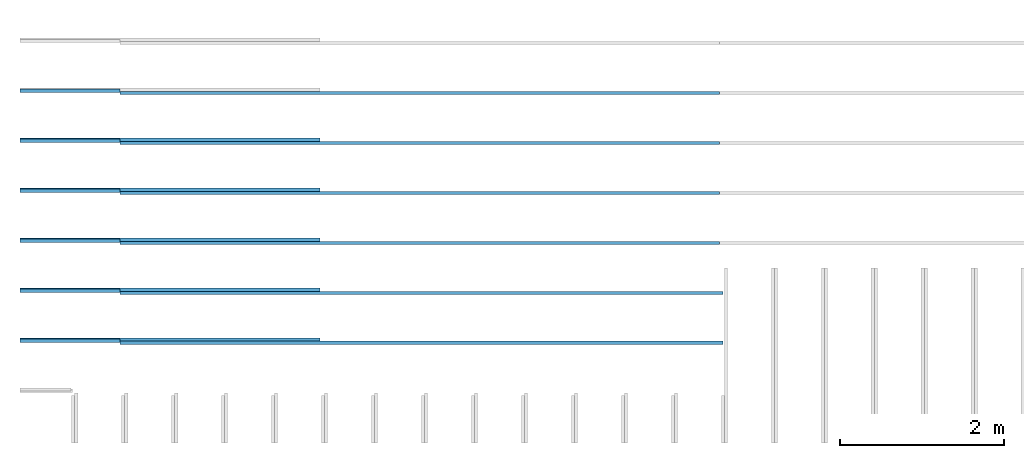
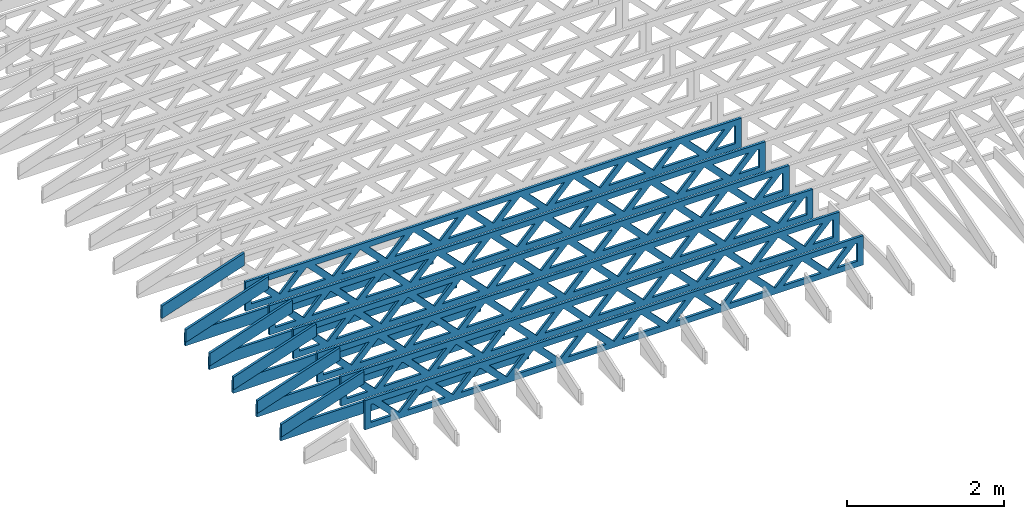
# One storey, part 1 of 17: 17 beams, 3 elements without a shape of their own.
"""IFC4 building model written with IfcOpenShell, lengths in feet."""

from ifc_helpers import new_model, entity, si_unit, converted_unit, derived_unit, direction, frame, frame_2d, origin, origin_2d_with_axis, place, context, subcontext, project, spatial, rectangle, extrude, clip, halfspace, source, transform, mapped, material, material_profile, profile_set, profile_usage, type_object, type_shapes, element, aggregate, save


model = new_model("IFC4")

# Units and contexts
model_context = context("Model", 3, precision=0.0001, world=origin(), true_north=direction((6.12303176911189e-17, 1.0)))
body_context = subcontext(model_context, "Body", "Model", "MODEL_VIEW")
ifc_project = project(units=[converted_unit("LENGTHUNIT", "FOOT", entity("IfcRatioMeasure", 0.3048), si_unit("LENGTHUNIT", "METRE"), dimensions=[1, 0, 0, 0, 0, 0, 0]), converted_unit("AREAUNIT", "SQUARE FOOT", entity("IfcRatioMeasure", 0.09290304), si_unit("AREAUNIT", "SQUARE_METRE"), dimensions=[2, 0, 0, 0, 0, 0, 0]), converted_unit("VOLUMEUNIT", "CUBIC FOOT", entity("IfcRatioMeasure", 0.028316846592), si_unit("VOLUMEUNIT", "CUBIC_METRE"), dimensions=[3, 0, 0, 0, 0, 0, 0]), converted_unit("PLANEANGLEUNIT", "DEGREE", entity("IfcRatioMeasure", 0.0174532925199433), si_unit("PLANEANGLEUNIT", "RADIAN"), dimensions=[0, 0, 0, 0, 0, 0, 0]), si_unit("MASSUNIT", "GRAM", prefix="KILO"), derived_unit("MASSDENSITYUNIT", [(si_unit("MASSUNIT", "GRAM", prefix="KILO"), 1), (si_unit("LENGTHUNIT", "METRE"), -3)]), derived_unit("MOMENTOFINERTIAUNIT", [(si_unit("LENGTHUNIT", "METRE"), 4)]), si_unit("TIMEUNIT", "SECOND"), si_unit("FREQUENCYUNIT", "HERTZ"), si_unit("THERMODYNAMICTEMPERATUREUNIT", "DEGREE_CELSIUS"), derived_unit("THERMALTRANSMITTANCEUNIT", [(si_unit("MASSUNIT", "GRAM", prefix="KILO"), 1), (si_unit("THERMODYNAMICTEMPERATUREUNIT", "KELVIN"), -1), (si_unit("TIMEUNIT", "SECOND"), -3)]), derived_unit("VOLUMETRICFLOWRATEUNIT", [(si_unit("LENGTHUNIT", "METRE"), 3), (si_unit("TIMEUNIT", "SECOND"), -1)]), si_unit("ELECTRICCURRENTUNIT", "AMPERE"), si_unit("ELECTRICVOLTAGEUNIT", "VOLT"), si_unit("POWERUNIT", "WATT"), si_unit("FORCEUNIT", "NEWTON"), si_unit("ILLUMINANCEUNIT", "LUX"), si_unit("LUMINOUSFLUXUNIT", "LUMEN"), si_unit("LUMINOUSINTENSITYUNIT", "CANDELA"), derived_unit("USERDEFINED", [(si_unit("MASSUNIT", "GRAM", prefix="KILO"), -1), (si_unit("LENGTHUNIT", "METRE"), -2), (si_unit("TIMEUNIT", "SECOND"), 3), (si_unit("LUMINOUSFLUXUNIT", "LUMEN"), 1)]), derived_unit("LINEARVELOCITYUNIT", [(si_unit("LENGTHUNIT", "METRE"), 1), (si_unit("TIMEUNIT", "SECOND"), -1)]), si_unit("PRESSUREUNIT", "PASCAL"), derived_unit("USERDEFINED", [(si_unit("LENGTHUNIT", "METRE"), -2), (si_unit("MASSUNIT", "GRAM", prefix="KILO"), 1), (si_unit("TIMEUNIT", "SECOND"), -2)]), derived_unit("LINEARFORCEUNIT", [(si_unit("MASSUNIT", "GRAM", prefix="KILO"), 1), (si_unit("LENGTHUNIT", "METRE"), 1), (si_unit("TIMEUNIT", "SECOND"), -2), (si_unit("LENGTHUNIT", "METRE"), -1)]), derived_unit("PLANARFORCEUNIT", [(si_unit("MASSUNIT", "GRAM", prefix="KILO"), 1), (si_unit("LENGTHUNIT", "METRE"), 1), (si_unit("TIMEUNIT", "SECOND"), -2), (si_unit("LENGTHUNIT", "METRE"), -2)])], contexts=[model_context])

# Site, building, storey
site_placement = place(None, origin())
site = spatial("IfcSite", under=ifc_project, at=site_placement, CompositionType="ELEMENT")
building_placement = place(site_placement, origin())
building = spatial("IfcBuilding", under=site, at=building_placement, CompositionType="ELEMENT")
storey_placement = place(building_placement, frame((0.0, 0.0, 30.4375000000082)))
storey = spatial("IfcBuildingStorey", under=building, at=storey_placement, Name="ROOF", CompositionType="ELEMENT", Elevation=30.4375000000082)

# Assembly, beams
assembly_1_placement = place(storey_placement, origin())
assembly_1 = element("IfcElementAssembly", 1, at=assembly_1_placement, inside=storey, Name="Structural Beam System:Structural Framing System", ObjectType="Structural Beam System:Structural Framing System", AssemblyPlace="NOTDEFINED", PredefinedType="BEAM_GRID")
ifc_material_1 = material(Name="WOOD TRUSS", Category="Materials")
ifc_material_profile_1 = material_profile(ifc_material_1, rectangle(XDim=1.73473973950632, YDim=0.125, at=origin_2d_with_axis()))
ifc_material_profile_2 = material_profile(ifc_material_1, rectangle(XDim=1.73473973950633, YDim=0.125, at=frame_2d((-1.11022302462516e-16, 0.0), x_axis=(1.0, 0.0))))
ifc_material_profile_3 = material_profile(ifc_material_1, rectangle(XDim=1.73473973950632, YDim=0.125, at=origin_2d_with_axis()))
ifc_material_profile_4 = material_profile(ifc_material_1, rectangle(XDim=1.73473973950633, YDim=0.125, at=origin_2d_with_axis()))
ifc_material_profile_5 = material_profile(ifc_material_1, rectangle(XDim=1.73473973950632, YDim=0.125, at=frame_2d((-5.55111512312578e-17, 0.0), x_axis=(1.0, 0.0))))
ifc_material_profile_6 = material_profile(ifc_material_1, rectangle(XDim=1.73473973950633, YDim=0.125, at=frame_2d((-2.77555756156289e-16, 0.0), x_axis=(1.0, 0.0))))
ifc_material_profile_7 = material_profile(ifc_material_1, rectangle(XDim=1.73473973950632, YDim=0.125, at=frame_2d((-4.9960036108132e-16, 0.0), x_axis=(1.0, 0.0))))
ifc_material_profile_8 = material_profile(ifc_material_1, rectangle(XDim=1.73473973950633, YDim=0.125, at=frame_2d((4.44089209850063e-16, 0.0), x_axis=(1.0, 0.0))))
ifc_material_profile_9 = material_profile(ifc_material_1, rectangle(XDim=1.73473973950632, YDim=0.125, at=origin_2d_with_axis()))
ifc_material_profile_10 = material_profile(ifc_material_1, rectangle(XDim=1.73473973950633, YDim=0.125, at=frame_2d((-4.9960036108132e-16, 0.0), x_axis=(1.0, 0.0))))
ifc_material_profile_11 = material_profile(ifc_material_1, rectangle(XDim=0.291666666666664, YDim=0.125, at=frame_2d((-2.77555756156289e-17, 0.0), x_axis=(1.0, 0.0))))
ifc_material_profile_12 = material_profile(ifc_material_1, rectangle(XDim=0.291666666666628, YDim=0.124999999999995, at=frame_2d((-5.55111512312578e-17, 0.0), x_axis=(1.0, 0.0))))
ifc_material_profile_13 = material_profile(ifc_material_1, rectangle(XDim=0.916666666666666, YDim=0.125000000000003, at=frame_2d((-2.77555756156289e-17, 0.0), x_axis=(1.0, 0.0))))
ifc_material_profile_14 = material_profile(ifc_material_1, rectangle(XDim=0.916666666666651, YDim=0.125, at=frame_2d((-2.77555756156289e-17, 0.0), x_axis=(1.0, 0.0))))
ifc_profile_set_1 = profile_set([ifc_material_profile_1, ifc_material_profile_2, ifc_material_profile_3, ifc_material_profile_4, ifc_material_profile_5, ifc_material_profile_6, ifc_material_profile_7, ifc_material_profile_8, ifc_material_profile_9, ifc_material_profile_10, ifc_material_profile_11, ifc_material_profile_12, ifc_material_profile_13, ifc_material_profile_14])
ifc_profile_usage_1 = profile_usage(ifc_profile_set_1, cardinal=8)
beam_type_1 = type_object("IfcBeamType", PredefinedType="BEAM", material=ifc_profile_set_1)
shared_shape_1 = source(origin(), body_context, "Body", "SweptSolid", [
    extrude(rectangle(XDim=1.73473973950632, YDim=0.125, at=frame_2d((8.88178419700125e-16, 0.0), x_axis=(1.0, 0.0))), frame((8.27006284966195, 0.0, 0.101118361020562), z_axis=(0.720569184836762, 0.0, -0.693383046997606), x_axis=(0.693383046997606, 0.0, 0.720569184836762)), (0.0, 0.0, 1.0), 0.291666666666667),
    extrude(rectangle(XDim=1.73473973950633, YDim=0.125, at=frame_2d((4.9960036108132e-16, 0.0), x_axis=(1.0, 0.0))), frame((7.01977697598868, 0.0, -0.101118361020407), z_axis=(0.720569184836758, 0.0, 0.69338304699761), x_axis=(0.69338304699761, 0.0, -0.720569184836758)), (0.0, 0.0, 1.0), 0.291666666666667),
    extrude(rectangle(XDim=1.73473973950632, YDim=0.125, at=origin_2d_with_axis()), frame((5.68672854334628, 0.0, 0.101118361020562), z_axis=(0.720569184836762, 0.0, -0.693383046997606), x_axis=(0.693383046997606, 0.0, 0.720569184836762)), (0.0, 0.0, 1.0), 0.291666666666667),
    extrude(rectangle(XDim=1.73473973950633, YDim=0.125, at=frame_2d((-4.9960036108132e-16, 0.0), x_axis=(1.0, 0.0))), frame((4.43644266967301, 0.0, -0.101118361020407), z_axis=(0.720569184836758, 0.0, 0.69338304699761), x_axis=(0.69338304699761, 0.0, -0.720569184836758)), (0.0, 0.0, 1.0), 0.291666666666667),
    extrude(rectangle(XDim=1.73473973950632, YDim=0.125, at=frame_2d((3.33066907387547e-16, 0.0), x_axis=(1.0, 0.0))), frame((3.10339423703061, 0.0, 0.101118361020562), z_axis=(0.720569184836762, 0.0, -0.693383046997606), x_axis=(0.693383046997606, 0.0, 0.720569184836762)), (0.0, 0.0, 1.0), 0.291666666666667),
    extrude(rectangle(XDim=1.73473973950633, YDim=0.125, at=frame_2d((-1.11022302462516e-16, 0.0), x_axis=(1.0, 0.0))), frame((1.85310836335734, 0.0, -0.101118361020407), z_axis=(0.720569184836758, 0.0, 0.69338304699761), x_axis=(0.69338304699761, 0.0, -0.720569184836758)), (0.0, 0.0, 1.0), 0.291666666666666),
    extrude(rectangle(XDim=1.73473973950632, YDim=0.125, at=frame_2d((5.55111512312578e-17, 0.0), x_axis=(1.0, 0.0))), frame((0.520059930714937, 0.0, 0.101118361020562), z_axis=(0.720569184836762, 0.0, -0.693383046997606), x_axis=(0.693383046997606, 0.0, 0.720569184836762)), (0.0, 0.0, 1.0), 0.291666666666667),
    extrude(rectangle(XDim=1.73473973950633, YDim=0.125, at=origin_2d_with_axis()), frame((-0.730225942958334, 0.0, -0.101118361020407), z_axis=(0.720569184836758, 0.0, 0.69338304699761), x_axis=(0.69338304699761, 0.0, -0.720569184836758)), (0.0, 0.0, 1.0), 0.291666666666666),
    extrude(rectangle(XDim=1.73473973950632, YDim=0.125, at=frame_2d((-5.55111512312578e-17, 0.0), x_axis=(1.0, 0.0))), frame((-2.06327437560074, 0.0, 0.101118361020562), z_axis=(0.720569184836762, 0.0, -0.693383046997606), x_axis=(0.693383046997606, 0.0, 0.720569184836762)), (0.0, 0.0, 1.0), 0.291666666666667),
    extrude(rectangle(XDim=1.73473973950633, YDim=0.125, at=frame_2d((-2.77555756156289e-16, 0.0), x_axis=(1.0, 0.0))), frame((-3.31356024927401, 0.0, -0.101118361020407), z_axis=(0.720569184836758, 0.0, 0.69338304699761), x_axis=(0.69338304699761, 0.0, -0.720569184836758)), (0.0, 0.0, 1.0), 0.291666666666666),
    extrude(rectangle(XDim=1.73473973950632, YDim=0.125, at=origin_2d_with_axis()), frame((-4.64660868191641, 0.0, 0.101118361020562), z_axis=(0.720569184836762, 0.0, -0.693383046997606), x_axis=(0.693383046997606, 0.0, 0.720569184836762)), (0.0, 0.0, 1.0), 0.291666666666667),
    extrude(rectangle(XDim=1.73473973950633, YDim=0.125, at=frame_2d((-4.9960036108132e-16, 0.0), x_axis=(1.0, 0.0))), frame((-5.89689455558968, 0.0, -0.101118361020407), z_axis=(0.720569184836758, 0.0, 0.69338304699761), x_axis=(0.69338304699761, 0.0, -0.720569184836758)), (0.0, 0.0, 1.0), 0.291666666666667),
    extrude(rectangle(XDim=1.73473973950632, YDim=0.125, at=frame_2d((5.55111512312578e-16, 0.0), x_axis=(1.0, 0.0))), frame((-7.22994298823208, 0.0, 0.101118361020562), z_axis=(0.720569184836762, 0.0, -0.693383046997606), x_axis=(0.693383046997606, 0.0, 0.720569184836762)), (0.0, 0.0, 1.0), 0.291666666666667),
    extrude(rectangle(XDim=1.73473973950633, YDim=0.125, at=origin_2d_with_axis()), frame((-8.48022886190535, 0.0, -0.101118361020407), z_axis=(0.720569184836758, 0.0, 0.69338304699761), x_axis=(0.69338304699761, 0.0, -0.720569184836758)), (0.0, 0.0, 1.0), 0.291666666666666),
    extrude(rectangle(XDim=1.73473973950632, YDim=0.125, at=frame_2d((-8.88178419700125e-16, 0.0), x_axis=(1.0, 0.0))), frame((10.8533971559776, 0.0, 0.101118361020503), z_axis=(0.720569184836762, 0.0, -0.693383046997606), x_axis=(0.693383046997606, 0.0, 0.720569184836762)), (0.0, 0.0, 1.0), 0.291666666666664),
    extrude(rectangle(XDim=1.73473973950633, YDim=0.125, at=origin_2d_with_axis()), frame((9.60311128230435, 0.0, -0.101118361020466), z_axis=(0.720569184836758, 0.0, 0.69338304699761), x_axis=(0.69338304699761, 0.0, -0.720569184836758)), (0.0, 0.0, 1.0), 0.291666666666666),
    extrude(rectangle(XDim=1.73473973950632, YDim=0.125, at=frame_2d((8.88178419700125e-16, 0.0), x_axis=(1.0, 0.0))), frame((-9.81327729454775, 0.0, 0.101118361020564), z_axis=(0.720569184836762, 0.0, -0.693383046997606), x_axis=(0.693383046997606, 0.0, 0.720569184836762)), (0.0, 0.0, 1.0), 0.291666666666667),
    extrude(rectangle(XDim=1.73473973950633, YDim=0.125, at=origin_2d_with_axis()), frame((-11.063563168221, 0.0, -0.101118361020405), z_axis=(0.720569184836758, 0.0, 0.69338304699761), x_axis=(0.69338304699761, 0.0, -0.720569184836758)), (0.0, 0.0, 1.0), 0.291666666666666),
    extrude(rectangle(XDim=0.291666666666664, YDim=0.125, at=frame_2d((-2.77555756156289e-17, 0.0), x_axis=(1.0, 0.0))), frame((-12.0000038919293, 0.0, 0.604166666666611), z_axis=(1.0, 0.0, 0.0), x_axis=(0.0, 0.0, -1.0)), (0.0, 0.0, 1.0), 24.0000077838585),
    extrude(rectangle(XDim=0.291666666666628, YDim=0.124999999999995, at=frame_2d((-5.55111512312578e-17, 0.0), x_axis=(1.0, 0.0))), frame((-12.0000038919291, 0.0, -0.604166666666693), z_axis=(1.0, 0.0, 0.0), x_axis=(0.0, 0.0, -1.0)), (0.0, 0.0, 1.0), 24.0000077838583),
    extrude(rectangle(XDim=0.916666666666666, YDim=0.125000000000003, at=frame_2d((-2.77555756156289e-17, 0.0), x_axis=(1.0, 0.0))), frame((11.7083372252626, 0.0, 0.0), z_axis=(1.0, 0.0, 0.0), x_axis=(0.0, 0.0, -1.0)), (0.0, 0.0, 1.0), 0.291666666666687),
    extrude(rectangle(XDim=0.916666666666651, YDim=0.125, at=frame_2d((-2.77555756156289e-17, 0.0), x_axis=(1.0, 0.0))), frame((-12.0000038919293, 0.0, 0.0), z_axis=(1.0, 0.0, 0.0), x_axis=(0.0, 0.0, -1.0)), (0.0, 0.0, 1.0), 0.291666666666687),
])
type_shapes(beam_type_1, [shared_shape_1])
beam_1_placement = place(assembly_1_placement, frame((-253.738164377457, 935.861934882651, 0.749999999991672)))
beam_1 = element("IfcBeam", 2, at=beam_1_placement, type_object=beam_type_1, material=ifc_profile_usage_1, PredefinedType="BEAM", context=body_context, shape_type="MappedRepresentation", body=[
    mapped(shared_shape_1, transform((0.0, 0.0, 0.0), scale=1.0)),
])
ifc_profile_usage_2 = profile_usage(ifc_profile_set_1, cardinal=8)
beam_2_placement = place(assembly_1_placement, frame((-253.738164377457, 933.861934882651, 0.74999999999168)))
beam_2 = element("IfcBeam", 3, at=beam_2_placement, type_object=beam_type_1, material=ifc_profile_usage_2, PredefinedType="BEAM", context=body_context, shape_type="MappedRepresentation", body=[
    mapped(shared_shape_1, transform((0.0, 0.0, 0.0), scale=1.0)),
])
ifc_profile_usage_3 = profile_usage(ifc_profile_set_1, cardinal=8)
beam_3_placement = place(assembly_1_placement, frame((-253.738164377457, 931.861934882651, 0.749999999991687)))
beam_3 = element("IfcBeam", 4, at=beam_3_placement, type_object=beam_type_1, material=ifc_profile_usage_3, PredefinedType="BEAM", context=body_context, shape_type="MappedRepresentation", body=[
    mapped(shared_shape_1, transform((0.0, 0.0, 0.0), scale=1.0)),
])
ifc_profile_usage_4 = profile_usage(ifc_profile_set_1, cardinal=8)
beam_4_placement = place(assembly_1_placement, frame((-253.738164377457, 929.861934882651, 0.74999999999169)))
beam_4 = element("IfcBeam", 5, at=beam_4_placement, type_object=beam_type_1, material=ifc_profile_usage_4, PredefinedType="BEAM", context=body_context, shape_type="MappedRepresentation", body=[
    mapped(shared_shape_1, transform((0.0, 0.0, 0.0), scale=1.0)),
])
ifc_profile_usage_5 = profile_usage(ifc_profile_set_1, cardinal=8)
beam_type_2 = type_object("IfcBeamType", PredefinedType="BEAM", material=ifc_profile_set_1)
shared_shape_2 = source(origin(), body_context, "Body", "SweptSolid", [
    extrude(rectangle(XDim=1.73473973950632, YDim=0.125, at=frame_2d((8.88178419700125e-16, 0.0), x_axis=(1.0, 0.0))), frame((8.31693784968716, 0.0, 0.101118361020562), z_axis=(0.720569184836762, 0.0, -0.693383046997606), x_axis=(0.693383046997606, 0.0, 0.720569184836762)), (0.0, 0.0, 1.0), 0.291666666666667),
    extrude(rectangle(XDim=1.73473973950633, YDim=0.125, at=frame_2d((4.9960036108132e-16, 0.0), x_axis=(1.0, 0.0))), frame((7.06665197601389, 0.0, -0.101118361020407), z_axis=(0.720569184836758, 0.0, 0.69338304699761), x_axis=(0.69338304699761, 0.0, -0.720569184836758)), (0.0, 0.0, 1.0), 0.291666666666667),
    extrude(rectangle(XDim=1.73473973950632, YDim=0.125, at=origin_2d_with_axis()), frame((5.71797854336309, 0.0, 0.101118361020562), z_axis=(0.720569184836762, 0.0, -0.693383046997606), x_axis=(0.693383046997606, 0.0, 0.720569184836762)), (0.0, 0.0, 1.0), 0.291666666666667),
    extrude(rectangle(XDim=1.73473973950633, YDim=0.125, at=frame_2d((-4.9960036108132e-16, 0.0), x_axis=(1.0, 0.0))), frame((4.46769266968982, 0.0, -0.101118361020407), z_axis=(0.720569184836758, 0.0, 0.69338304699761), x_axis=(0.69338304699761, 0.0, -0.720569184836758)), (0.0, 0.0, 1.0), 0.291666666666667),
    extrude(rectangle(XDim=1.73473973950632, YDim=0.125, at=frame_2d((3.33066907387547e-16, 0.0), x_axis=(1.0, 0.0))), frame((3.11901923703901, 0.0, 0.101118361020562), z_axis=(0.720569184836762, 0.0, -0.693383046997606), x_axis=(0.693383046997606, 0.0, 0.720569184836762)), (0.0, 0.0, 1.0), 0.291666666666667),
    extrude(rectangle(XDim=1.73473973950633, YDim=0.125, at=frame_2d((-1.11022302462516e-16, 0.0), x_axis=(1.0, 0.0))), frame((1.86873336336574, 0.0, -0.101118361020407), z_axis=(0.720569184836758, 0.0, 0.69338304699761), x_axis=(0.69338304699761, 0.0, -0.720569184836758)), (0.0, 0.0, 1.0), 0.291666666666666),
    extrude(rectangle(XDim=1.73473973950632, YDim=0.125, at=frame_2d((5.55111512312578e-17, 0.0), x_axis=(1.0, 0.0))), frame((0.520059930714937, 0.0, 0.101118361020562), z_axis=(0.720569184836762, 0.0, -0.693383046997606), x_axis=(0.693383046997606, 0.0, 0.720569184836762)), (0.0, 0.0, 1.0), 0.291666666666667),
    extrude(rectangle(XDim=1.73473973950633, YDim=0.125, at=origin_2d_with_axis()), frame((-0.730225942958334, 0.0, -0.101118361020407), z_axis=(0.720569184836758, 0.0, 0.69338304699761), x_axis=(0.69338304699761, 0.0, -0.720569184836758)), (0.0, 0.0, 1.0), 0.291666666666666),
    extrude(rectangle(XDim=1.73473973950632, YDim=0.125, at=frame_2d((-5.55111512312578e-17, 0.0), x_axis=(1.0, 0.0))), frame((-2.07889937560914, 0.0, 0.101118361020562), z_axis=(0.720569184836762, 0.0, -0.693383046997606), x_axis=(0.693383046997606, 0.0, 0.720569184836762)), (0.0, 0.0, 1.0), 0.291666666666667),
    extrude(rectangle(XDim=1.73473973950633, YDim=0.125, at=frame_2d((-2.77555756156289e-16, 0.0), x_axis=(1.0, 0.0))), frame((-3.32918524928241, 0.0, -0.101118361020407), z_axis=(0.720569184836758, 0.0, 0.69338304699761), x_axis=(0.69338304699761, 0.0, -0.720569184836758)), (0.0, 0.0, 1.0), 0.291666666666666),
    extrude(rectangle(XDim=1.73473973950632, YDim=0.125, at=origin_2d_with_axis()), frame((-4.67785868193321, 0.0, 0.101118361020562), z_axis=(0.720569184836762, 0.0, -0.693383046997606), x_axis=(0.693383046997606, 0.0, 0.720569184836762)), (0.0, 0.0, 1.0), 0.291666666666667),
    extrude(rectangle(XDim=1.73473973950633, YDim=0.125, at=frame_2d((-4.9960036108132e-16, 0.0), x_axis=(1.0, 0.0))), frame((-5.92814455560648, 0.0, -0.101118361020407), z_axis=(0.720569184836758, 0.0, 0.69338304699761), x_axis=(0.69338304699761, 0.0, -0.720569184836758)), (0.0, 0.0, 1.0), 0.291666666666667),
    extrude(rectangle(XDim=1.73473973950632, YDim=0.125, at=frame_2d((-5.55111512312578e-16, 0.0), x_axis=(1.0, 0.0))), frame((-7.27681798825729, 0.0, 0.101118361020562), z_axis=(0.720569184836762, 0.0, -0.693383046997606), x_axis=(0.693383046997606, 0.0, 0.720569184836762)), (0.0, 0.0, 1.0), 0.291666666666667),
    extrude(rectangle(XDim=1.73473973950633, YDim=0.125, at=origin_2d_with_axis()), frame((-8.52710386193056, 0.0, -0.101118361020407), z_axis=(0.720569184836758, 0.0, 0.69338304699761), x_axis=(0.69338304699761, 0.0, -0.720569184836758)), (0.0, 0.0, 1.0), 0.291666666666666),
    extrude(rectangle(XDim=1.73473973950632, YDim=0.125, at=frame_2d((-1.0547118733939e-15, 0.0), x_axis=(1.0, 0.0))), frame((10.9158971560112, 0.0, 0.101118361020503), z_axis=(0.720569184836762, 0.0, -0.693383046997606), x_axis=(0.693383046997606, 0.0, 0.720569184836762)), (0.0, 0.0, 1.0), 0.291666666666664),
    extrude(rectangle(XDim=1.73473973950633, YDim=0.125, at=origin_2d_with_axis()), frame((9.66561128233796, 0.0, -0.101118361020466), z_axis=(0.720569184836758, 0.0, 0.69338304699761), x_axis=(0.69338304699761, 0.0, -0.720569184836758)), (0.0, 0.0, 1.0), 0.291666666666666),
    extrude(rectangle(XDim=1.73473973950632, YDim=0.125, at=frame_2d((9.43689570931383e-16, 0.0), x_axis=(1.0, 0.0))), frame((-9.87577729458136, 0.0, 0.101118361020564), z_axis=(0.720569184836762, 0.0, -0.693383046997606), x_axis=(0.693383046997606, 0.0, 0.720569184836762)), (0.0, 0.0, 1.0), 0.291666666666667),
    extrude(rectangle(XDim=1.73473973950633, YDim=0.125, at=origin_2d_with_axis()), frame((-11.1260631682546, 0.0, -0.101118361020405), z_axis=(0.720569184836758, 0.0, 0.69338304699761), x_axis=(0.69338304699761, 0.0, -0.720569184836758)), (0.0, 0.0, 1.0), 0.291666666666666),
    extrude(rectangle(XDim=0.291666666666664, YDim=0.125, at=frame_2d((-2.77555756156289e-17, 0.0), x_axis=(1.0, 0.0))), frame((-12.0625038919629, 0.0, 0.604166666666611), z_axis=(1.0, 0.0, 0.0), x_axis=(0.0, 0.0, -1.0)), (0.0, 0.0, 1.0), 24.1250077839258),
    extrude(rectangle(XDim=0.291666666666628, YDim=0.124999999999995, at=frame_2d((-5.55111512312578e-17, 0.0), x_axis=(1.0, 0.0))), frame((-12.0625038919627, 0.0, -0.604166666666693), z_axis=(1.0, 0.0, 0.0), x_axis=(0.0, 0.0, -1.0)), (0.0, 0.0, 1.0), 24.1250077839255),
    extrude(rectangle(XDim=0.916666666666666, YDim=0.125000000000003, at=frame_2d((-2.77555756156289e-17, 0.0), x_axis=(1.0, 0.0))), frame((11.7708372252962, 0.0, 0.0), z_axis=(1.0, 0.0, 0.0), x_axis=(0.0, 0.0, -1.0)), (0.0, 0.0, 1.0), 0.291666666666687),
    extrude(rectangle(XDim=0.916666666666651, YDim=0.125, at=frame_2d((-2.77555756156289e-17, -6.93889390390723e-18), x_axis=(1.0, 0.0))), frame((-12.0625038919629, 0.0, 0.0), z_axis=(1.0, 0.0, 0.0), x_axis=(0.0, 0.0, -1.0)), (0.0, 0.0, 1.0), 0.291666666666687),
])
type_shapes(beam_type_2, [shared_shape_2])
beam_5_placement = place(assembly_1_placement, frame((-253.675664377424, 927.861934882651, 0.749999999991697)))
beam_5 = element("IfcBeam", 6, at=beam_5_placement, type_object=beam_type_2, material=ifc_profile_usage_5, PredefinedType="BEAM", context=body_context, shape_type="MappedRepresentation", body=[
    mapped(shared_shape_2, transform((0.0, 0.0, 0.0), scale=1.0)),
])
ifc_profile_usage_6 = profile_usage(ifc_profile_set_1, cardinal=8)
beam_6_placement = place(assembly_1_placement, frame((-253.675664377424, 925.861934882651, 0.749999999991701)))
beam_6 = element("IfcBeam", 7, at=beam_6_placement, type_object=beam_type_2, material=ifc_profile_usage_6, PredefinedType="BEAM", context=body_context, shape_type="MappedRepresentation", body=[
    mapped(shared_shape_2, transform((0.0, 0.0, 0.0), scale=1.0)),
])
aggregate(assembly_1, [beam_1, beam_2, beam_3, beam_4, beam_5, beam_6])

assembly_2_placement = place(storey_placement, origin())
assembly_2 = element("IfcElementAssembly", 8, at=assembly_2_placement, inside=storey, Name="Structural Beam System:Structural Framing System", ObjectType="Structural Beam System:Structural Framing System", AssemblyPlace="NOTDEFINED", PredefinedType="BEAM_GRID")
ifc_material_2 = material(Name="2X8 TO ROOF", Category="Materials")
ifc_material_profile_15 = material_profile(ifc_material_2, rectangle(XDim=0.604166666666667, YDim=0.125000000000011, at=origin_2d_with_axis()), Name="2X8")
ifc_profile_set_2 = profile_set([ifc_material_profile_15], Name="2X8")
ifc_profile_usage_7 = profile_usage(ifc_profile_set_2, cardinal=8)
beam_type_3 = type_object("IfcBeamType", Name="061100 - Wood Framing:2X8", PredefinedType="BEAM", material=ifc_profile_set_2)
shared_shape_3 = source(origin(), body_context, "Body", "SweptSolid", [
    extrude(rectangle(XDim=0.604166666666667, YDim=0.125000000000011, at=origin_2d_with_axis()), frame((-6.0, 0.0, 0.0), z_axis=(1.0, 0.0, 0.0), x_axis=(0.0, 0.0, -1.0)), (0.0, 0.0, 1.0), 12.000000000033),
])
type_shapes(beam_type_3, [shared_shape_3])
beam_7_placement = place(assembly_2_placement, frame((-263.738268818055, 925.986939926517, 1.07291666665849), z_axis=(0.0, 0.0, 1.0), x_axis=(-1.0, 0.0, 0.0)))
beam_7 = element("IfcBeam", 9, at=beam_7_placement, type_object=beam_type_3, material=ifc_profile_usage_7, Name="061100 - Wood Framing:2X8", ObjectType="061100 - Wood Framing:2X8", PredefinedType="BEAM", context=body_context, shape_type="MappedRepresentation", body=[
    mapped(shared_shape_3, transform((0.0, 0.0, 0.0), scale=1.0)),
])
ifc_profile_usage_8 = profile_usage(ifc_profile_set_2, cardinal=8)
beam_8_placement = place(assembly_2_placement, frame((-263.738253742943, 927.98693992663, 1.07291666665848), z_axis=(0.0, 0.0, 1.0), x_axis=(-1.0, 0.0, 0.0)))
beam_8 = element("IfcBeam", 10, at=beam_8_placement, type_object=beam_type_3, material=ifc_profile_usage_8, Name="061100 - Wood Framing:2X8", ObjectType="061100 - Wood Framing:2X8", PredefinedType="BEAM", context=body_context, shape_type="MappedRepresentation", body=[
    mapped(shared_shape_3, transform((0.0, 0.0, 0.0), scale=1.0)),
])
ifc_profile_usage_9 = profile_usage(ifc_profile_set_2, cardinal=8)
beam_9_placement = place(assembly_2_placement, frame((-263.738238667831, 929.986939926744, 1.07291666665848), z_axis=(0.0, 0.0, 1.0), x_axis=(-1.0, 0.0, 0.0)))
beam_9 = element("IfcBeam", 11, at=beam_9_placement, type_object=beam_type_3, material=ifc_profile_usage_9, Name="061100 - Wood Framing:2X8", ObjectType="061100 - Wood Framing:2X8", PredefinedType="BEAM", context=body_context, shape_type="MappedRepresentation", body=[
    mapped(shared_shape_3, transform((0.0, 0.0, 0.0), scale=1.0)),
])
ifc_profile_usage_10 = profile_usage(ifc_profile_set_2, cardinal=8)
beam_10_placement = place(assembly_2_placement, frame((-263.738223592719, 931.986939926858, 1.07291666665847), z_axis=(0.0, 0.0, 1.0), x_axis=(-1.0, 0.0, 0.0)))
beam_10 = element("IfcBeam", 12, at=beam_10_placement, type_object=beam_type_3, material=ifc_profile_usage_10, Name="061100 - Wood Framing:2X8", ObjectType="061100 - Wood Framing:2X8", PredefinedType="BEAM", context=body_context, shape_type="MappedRepresentation", body=[
    mapped(shared_shape_3, transform((0.0, 0.0, 0.0), scale=1.0)),
])
ifc_profile_usage_11 = profile_usage(ifc_profile_set_2, cardinal=8)
beam_11_placement = place(assembly_2_placement, frame((-263.738208517606, 933.986939926972, 1.07291666665846), z_axis=(0.0, 0.0, 1.0), x_axis=(-1.0, 0.0, 0.0)))
beam_11 = element("IfcBeam", 13, at=beam_11_placement, type_object=beam_type_3, material=ifc_profile_usage_11, Name="061100 - Wood Framing:2X8", ObjectType="061100 - Wood Framing:2X8", PredefinedType="BEAM", context=body_context, shape_type="MappedRepresentation", body=[
    mapped(shared_shape_3, transform((0.0, 0.0, 0.0), scale=1.0)),
])
aggregate(assembly_2, [beam_7, beam_8, beam_9, beam_10, beam_11])

assembly_3_placement = place(storey_placement, origin())
assembly_3 = element("IfcElementAssembly", 14, at=assembly_3_placement, inside=storey, Name="Structural Beam System:Structural Framing System", ObjectType="Structural Beam System:Structural Framing System", AssemblyPlace="NOTDEFINED", PredefinedType="BEAM_GRID")
ifc_material_3 = material(Name="TOP CHORD OF FIELD FRAMED OVERHANG", Category="Materials")
ifc_material_profile_16 = material_profile(ifc_material_3, rectangle(XDim=0.604166666666667, YDim=0.125, at=origin_2d_with_axis()), Name="2X8 TOP CHORD")
ifc_profile_set_3 = profile_set([ifc_material_profile_16], Name="2X8 TOP CHORD")
ifc_profile_usage_12 = profile_usage(ifc_profile_set_3, cardinal=8)
beam_type_4 = type_object("IfcBeamType", Name="Dimension Lumber - Ends:2X8 TOP CHORD", PredefinedType="BEAM", material=ifc_profile_set_3)
shared_shape_4 = source(origin(), body_context, "Body", "Clipping", [
    clip(clip(extrude(rectangle(XDim=0.604166666666671, YDim=0.125, at=frame_2d((-1.83186799063151e-15, 0.0), x_axis=(1.0, 0.0))), frame((-2.10819527564865, 0.0, 0.0), z_axis=(1.0, 0.0, 0.0), x_axis=(0.0, 0.0, -1.0)), (0.0, 0.0, 1.0), 4.41772145980974), halfspace(frame((2.10819527564862, -0.0625000000000025, -0.302083333333339), z_axis=(0.948710608132914, 0.0, -0.316145823973807), x_axis=(0.0, 1.0, 0.0)), False)), halfspace(frame((-1.90686436713617, -0.0625000000000025, 0.302083333333328), z_axis=(-0.948710608132914, 0.0, 0.316145823973807), x_axis=(0.0, 1.0, 0.0)), False)),
])
type_shapes(beam_type_4, [shared_shape_4])
beam_12_placement = place(assembly_3_placement, frame((-267.833654839365, 925.945265019167, 1.93690371042361), z_axis=(-0.316227766016837, 0.0, 0.948683298050514), x_axis=(0.948683298050514, 0.0, 0.316227766016836)))
beam_12 = element("IfcBeam", 15, at=beam_12_placement, type_object=beam_type_4, material=ifc_profile_usage_12, Name="Dimension Lumber - Ends:2X8 TOP CHORD", ObjectType="Dimension Lumber - Ends:2X8 TOP CHORD", PredefinedType="BEAM", context=body_context, shape_type="MappedRepresentation", body=[
    mapped(shared_shape_4, transform((0.0, 0.0, 0.0), scale=1.0)),
])
ifc_profile_usage_13 = profile_usage(ifc_profile_set_3, cardinal=8)
beam_13_placement = place(assembly_3_placement, frame((-267.833654839365, 927.945265019167, 1.93690371042361), z_axis=(-0.316227766016837, 0.0, 0.948683298050514), x_axis=(0.948683298050514, 0.0, 0.316227766016836)))
beam_13 = element("IfcBeam", 16, at=beam_13_placement, type_object=beam_type_4, material=ifc_profile_usage_13, Name="Dimension Lumber - Ends:2X8 TOP CHORD", ObjectType="Dimension Lumber - Ends:2X8 TOP CHORD", PredefinedType="BEAM", context=body_context, shape_type="MappedRepresentation", body=[
    mapped(shared_shape_4, transform((0.0, 0.0, 0.0), scale=1.0)),
])
ifc_profile_usage_14 = profile_usage(ifc_profile_set_3, cardinal=8)
beam_14_placement = place(assembly_3_placement, frame((-267.833654839365, 929.945265019167, 1.93690371042361), z_axis=(-0.316227766016837, 0.0, 0.948683298050514), x_axis=(0.948683298050514, 0.0, 0.316227766016836)))
beam_14 = element("IfcBeam", 17, at=beam_14_placement, type_object=beam_type_4, material=ifc_profile_usage_14, Name="Dimension Lumber - Ends:2X8 TOP CHORD", ObjectType="Dimension Lumber - Ends:2X8 TOP CHORD", PredefinedType="BEAM", context=body_context, shape_type="MappedRepresentation", body=[
    mapped(shared_shape_4, transform((0.0, 0.0, 0.0), scale=1.0)),
])
ifc_profile_usage_15 = profile_usage(ifc_profile_set_3, cardinal=8)
beam_15_placement = place(assembly_3_placement, frame((-267.833654839365, 931.945265019167, 1.93690371042361), z_axis=(-0.316227766016837, 0.0, 0.948683298050514), x_axis=(0.948683298050514, 0.0, 0.316227766016836)))
beam_15 = element("IfcBeam", 18, at=beam_15_placement, type_object=beam_type_4, material=ifc_profile_usage_15, Name="Dimension Lumber - Ends:2X8 TOP CHORD", ObjectType="Dimension Lumber - Ends:2X8 TOP CHORD", PredefinedType="BEAM", context=body_context, shape_type="MappedRepresentation", body=[
    mapped(shared_shape_4, transform((0.0, 0.0, 0.0), scale=1.0)),
])
ifc_profile_usage_16 = profile_usage(ifc_profile_set_3, cardinal=8)
beam_16_placement = place(assembly_3_placement, frame((-267.833654839365, 933.945265019167, 1.93690371042361), z_axis=(-0.316227766016837, 0.0, 0.948683298050514), x_axis=(0.948683298050514, 0.0, 0.316227766016836)))
beam_16 = element("IfcBeam", 19, at=beam_16_placement, type_object=beam_type_4, material=ifc_profile_usage_16, Name="Dimension Lumber - Ends:2X8 TOP CHORD", ObjectType="Dimension Lumber - Ends:2X8 TOP CHORD", PredefinedType="BEAM", context=body_context, shape_type="MappedRepresentation", body=[
    mapped(shared_shape_4, transform((0.0, 0.0, 0.0), scale=1.0)),
])
ifc_profile_usage_17 = profile_usage(ifc_profile_set_3, cardinal=8)
beam_17_placement = place(assembly_3_placement, frame((-267.833654839365, 935.945265019167, 1.93690371042361), z_axis=(-0.316227766016837, 0.0, 0.948683298050514), x_axis=(0.948683298050514, 0.0, 0.316227766016836)))
beam_17 = element("IfcBeam", 20, at=beam_17_placement, type_object=beam_type_4, material=ifc_profile_usage_17, Name="Dimension Lumber - Ends:2X8 TOP CHORD", ObjectType="Dimension Lumber - Ends:2X8 TOP CHORD", PredefinedType="BEAM", context=body_context, shape_type="MappedRepresentation", body=[
    mapped(shared_shape_4, transform((0.0, 0.0, 0.0), scale=1.0)),
])
aggregate(assembly_3, [beam_12, beam_13, beam_14, beam_15, beam_16, beam_17])

save(model, "model.ifc")
